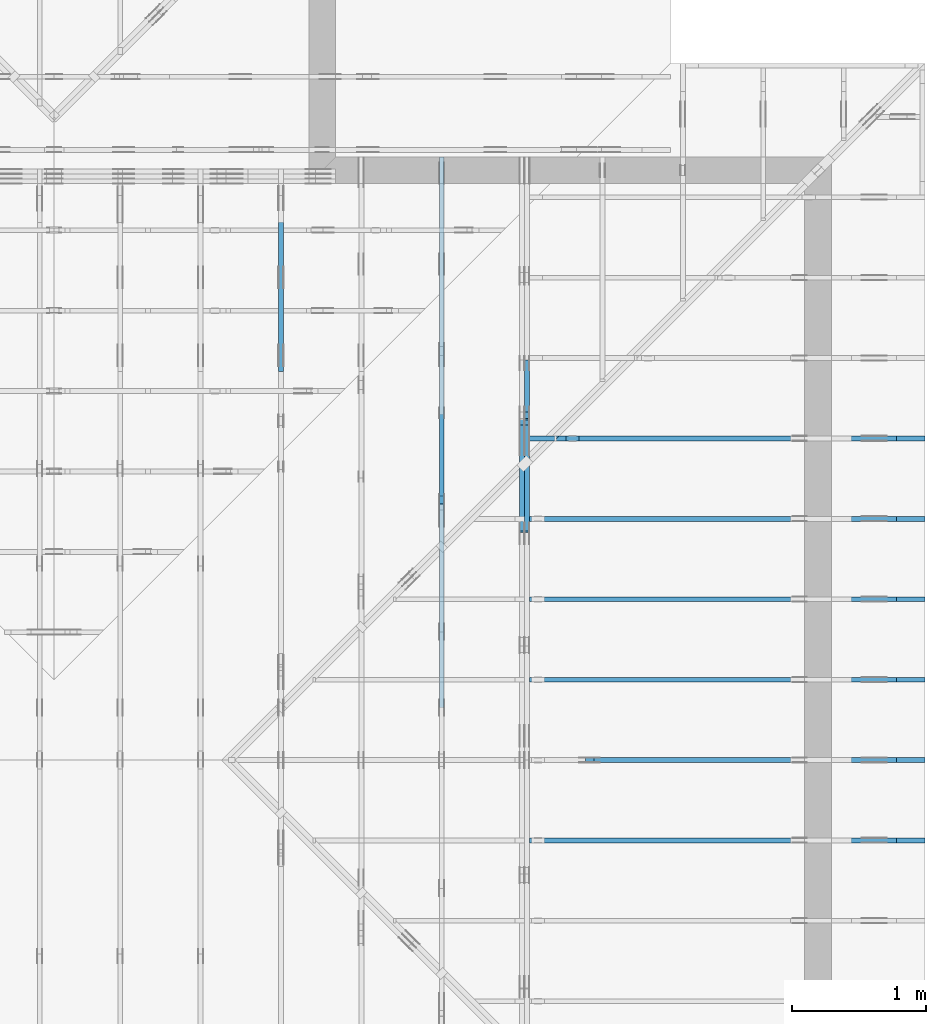
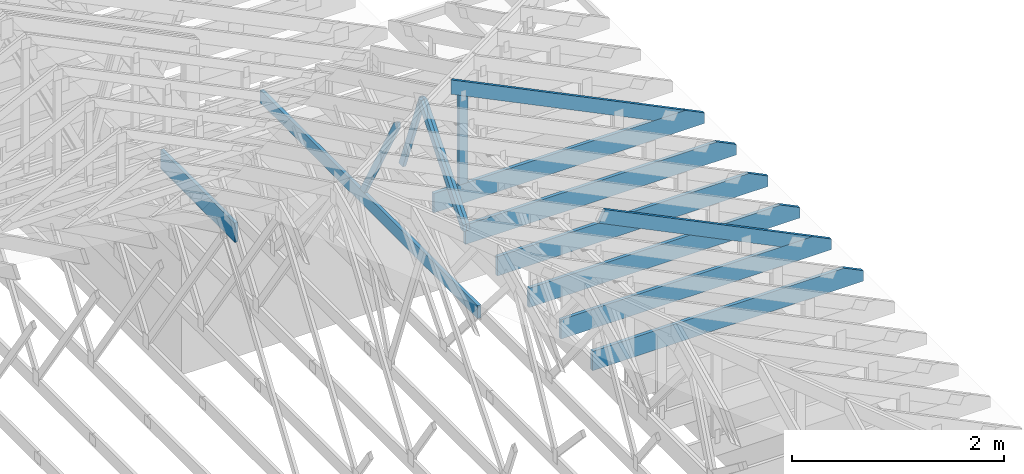
# One storey, part 35 of 159: 15 members, 9 elements without a shape of their own.
"""IFC2X3 building model written with IfcOpenShell, lengths in millimetres."""

from ifc_helpers import new_model, si_unit, frame, origin, origin_with_axes, origin_2d, place, context, project, spatial, faceted_brep, element, aggregate, save


model = new_model("IFC2X3")

# Units and contexts
model_context = context("Model", 3, precision=1e-05, world=origin())
plan_context = context("Plan", 2, precision=1e-05, world=origin_2d())
ifc_project = project(units=[si_unit("LENGTHUNIT", "METRE", prefix="MILLI"), si_unit("AREAUNIT", "SQUARE_METRE"), si_unit("VOLUMEUNIT", "CUBIC_METRE"), si_unit("SOLIDANGLEUNIT", "STERADIAN"), si_unit("PLANEANGLEUNIT", "RADIAN"), si_unit("MASSUNIT", "GRAM"), si_unit("TIMEUNIT", "SECOND"), si_unit("THERMODYNAMICTEMPERATUREUNIT", "DEGREE_CELSIUS"), si_unit("LUMINOUSINTENSITYUNIT", "LUMEN")], contexts=[model_context, plan_context])

# Site, building, storey
site_placement = place(None, origin_with_axes())
site = spatial("IfcSite", under=ifc_project, at=site_placement, CompositionType="ELEMENT")
building_placement = place(site_placement, origin_with_axes())
building = spatial("IfcBuilding", under=site, at=building_placement, Name="Plan 1", CompositionType="ELEMENT")
storey_placement = place(building_placement, origin_with_axes())
storey = spatial("IfcBuildingStorey", under=building, at=storey_placement, Name="Etasje 1", CompositionType="ELEMENT", Elevation=0.0)

# Assembly, member
assembly_1_placement = place(storey_placement, frame((16311.022261404749, -699.9989301294839, 1.1021457184401395e-15), z_axis=(1.0, -6.123031769111886e-17, 6.123031769111886e-17), x_axis=(6.123031769111886e-17, 1.0, 0.0)))
assembly_1 = element("IfcElementAssembly", 1, at=assembly_1_placement, inside=storey, Name="V8 (33)", AssemblyPlace="FACTORY", PredefinedType="TRUSS")
member_1_placement = place(assembly_1_placement, frame((8099.998930119851, 0.0, -36.0), z_axis=(0.0, 0.0, 1.0), x_axis=(1.0, 0.0, 0.0)))
member_1 = element("IfcMember", 2, at=member_1_placement, Name="V8-U19", context=model_context, shape_type="Brep", body=[
    faceted_brep([(1402.0000933176489, 223.0, 36.0), (9.331764886155725e-05, 223.0, 36.0), (9.331764886155725e-05, 0.0, 36.0), (1402.0000933176489, 0.0, 36.0), (9.331764886155725e-05, 223.0, 1.1427738571962853e-20), (1402.0000933176489, 223.0, 1.7168982223363585e-13), (1402.0000933176489, 0.0, 1.7168982223363585e-13), (9.331764886155725e-05, 0.0, 1.1427738571962853e-20), (0.0, 0.0, 0.0), (2.204291436880279e-15, -2.6993892992798474e-31, 36.0), (2.951301312711929e-14, 223.0, 36.0), (2.7308721690239013e-14, 223.0, -1.6721217048316832e-30), (1402.0, -2.5753471620884594e-13, 1.5768932489959775e-29), (1402.0, -2.5533042477196566e-13, 36.0), (4.049083948919771e-31, 2.204291436880279e-15, 36.0), (0.0, 0.0, 0.0), (1402.0, 223.0, 0.0), (1402.0, 223.0, 36.0), (1402.0, 0.0, 36.0), (1402.0, 0.0, 0.0), (0.0, 223.0, 0.0), (-1.3496946496399237e-31, 223.0, 36.0), (1402.0, 222.99999999999991, 36.0), (1402.0, 222.99999999999991, -4.733165431326071e-30)], [[[0, 1, 2, 3]], [[4, 5, 6, 7]], [[8, 9, 10, 11]], [[12, 13, 14, 15]], [[16, 17, 18, 19]], [[20, 21, 22, 23]]]),
])
aggregate(assembly_1, [member_1])

# Assembly, members
assembly_2_placement = place(storey_placement, frame((18074.541652722903, -699.9989301294845, 4.408582873760558e-15), z_axis=(-1.0, 1.836909530733566e-16, 6.123031769111886e-17), x_axis=(-1.836909530733566e-16, -1.0, 0.0)))
assembly_2 = element("IfcElementAssembly", 3, at=assembly_2_placement, inside=storey, Name="V5 (30)", AssemblyPlace="FACTORY", PredefinedType="TRUSS")
member_2_placement = place(assembly_2_placement, frame((-7784.008629309485, 1261.0239014078534, -71.99999999999999), z_axis=(0.0, 0.0, 1.0), x_axis=(-0.3612308951582944, -0.9324764020516215, 0.0)))
member_2 = element("IfcMember", 4, at=member_2_placement, Name="V5-D49", context=model_context, shape_type="Brep", body=[
    faceted_brep([(1084.9109850654727, 73.000426766278, 36.0), (62.15332242535737, 73.000426766278, 36.0), (6.463713430093776e-05, 36.500128102201415, 36.0), (39.3830811553712, 0.0001626723005756503, 36.0), (1113.1905312820863, 0.0001626723005756503, 36.0), (62.15332242535737, 73.000426766278, 7.611335355326349e-15), (1084.9109850654727, 73.000426766278, 1.328588885642872e-13), (1113.1905312820863, 0.0001626723005756503, 1.3632201976229506e-13), (39.3830811553712, 0.0001626723005756503, 4.82287714159699e-15), (6.463713430093776e-05, 36.500128102201415, 7.91550453577987e-21), (3.552713678800501e-15, 36.500210312128736, 0.0), (5.329070518200751e-15, 36.500210312128736, 36.0), (62.15334871027269, 73.00021031312829, 36.0), (62.15334871027269, 73.00021031312829, 7.888609052210118e-31), (39.38304675078666, 0.00021031312735075858, 1.9721522630525295e-31), (39.38304675078666, 0.00021031312735075858, 36.0), (7.105427357601002e-15, 36.50021031212874, 36.0), (7.105427357601002e-15, 36.50021031212874, -5.9164567891575885e-31), (1113.1904498091412, 0.00021031312619447325, 1.532860281653061e-29), (1113.1904498091412, 0.00021031312619667754, 36.0), (39.38304675078666, 0.0002103131273476588, 36.0), (39.38304675078666, 0.0002103131273454545, 5.423042565202193e-31), (1084.9110689169952, 73.00021031312644, 9.978856970719965e-31), (1084.9110689169952, 73.00021031312644, 36.0), (1113.1904498091412, 0.0002103131264448166, 36.0), (1113.1904498091412, 0.0002103131264448166, 1.2391235632630343e-30), (62.15334871027267, 73.00021031312826, 0.0), (62.15334871027267, 73.00021031312826, 36.0), (1084.9110689169952, 73.00021031312639, 36.0), (1084.9110689169952, 73.00021031312639, -3.944304526105059e-30)], [[[0, 1, 2, 3, 4]], [[5, 6, 7, 8, 9]], [[10, 11, 12, 13]], [[14, 15, 16, 17]], [[18, 19, 20, 21]], [[22, 23, 24, 25]], [[26, 27, 28, 29]]]),
])
member_3_placement = place(assembly_2_placement, frame((-7778.067645290552, 1224.537567565171, -36.0), z_axis=(0.0, 0.0, 1.0), x_axis=(0.6383914022219089, -0.7697119055654169, 0.0)))
member_3 = element("IfcMember", 5, at=member_3_placement, Name="V5-D38", context=model_context, shape_type="Brep", body=[
    faceted_brep([(1274.730361228223, 73.00027403103468, 36.0), (30.27278213358659, 73.00027403103468, 36.0), (0.0, 36.500021054841454, 36.0), (62.15355977314812, 0.00024289300472446484, 36.0), (1301.1849762534966, 0.00024289300472446484, 36.0), (1331.4577583870832, 36.500021054841454, 36.0), (30.27278213358659, 73.00027403103468, 3.707224134867068e-15), (1274.730361228223, 73.00027403103468, 1.5610428997703762e-13), (1331.4577583870832, 36.500021054841454, 1.6305116307669217e-13), (1301.1849762534966, 0.00024289300472446484, 1.5934393894182512e-13), (62.15355977314812, 0.00024289300472446484, 7.61136442108761e-15), (0.0, 36.500021054841454, 0.0), (4.0309500946023036e-05, 36.5001175513462, 0.0), (4.0309500946023036e-05, 36.5001175513462, 36.0), (30.272777437697194, 73.0001175521693, 36.0), (30.272777437697194, 73.0001175521693, -1.9721522630525295e-31), (62.15338902084478, 0.00011755217019882025, -3.944304526105059e-31), (62.15338902084478, 0.00011755217020237296, 36.0), (4.0309500946023036e-05, 36.500117551346186, 36.0), (4.030950094424668e-05, 36.500117551346186, 7.888609052210118e-31), (1301.1850737500954, 0.00011755216778175121, -1.928557785518386e-29), (1301.1850737500954, 0.0001175521677839555, 36.0), (62.15338902084477, 0.00011755217021251681, 36.0), (62.15338902084477, 0.00011755217021031252, -9.212099082196412e-31), (1331.4578108775677, 36.50011755220032, -1.262177448353619e-29), (1331.4578108775677, 36.50011755220032, 36.0), (1301.1850737500954, 0.00011755216746678343, 36.0), (1301.1850737500954, 0.00011755216746678343, 0.0), (1274.7302208736946, 73.00011755216656, 6.310887241768095e-30), (1274.7302208736946, 73.00011755216656, 36.0), (1331.4578108775677, 36.50011755220021, 36.0), (1331.4578108775677, 36.50011755220021, 0.0), (30.272777437697187, 73.00011755216929, 0.0), (30.272777437697187, 73.00011755216929, 36.0), (1274.7302208736946, 73.00011755216644, 36.0), (1274.7302208736946, 73.00011755216644, -7.099748146989106e-30)], [[[0, 1, 2, 3, 4, 5]], [[6, 7, 8, 9, 10, 11]], [[12, 13, 14, 15]], [[16, 17, 18, 19]], [[20, 21, 22, 23]], [[24, 25, 26, 27]], [[28, 29, 30, 31]], [[32, 33, 34, 35]]]),
])
member_4_placement = place(assembly_2_placement, frame((-7778.067645290552, 1224.537567565171, -72.0), z_axis=(0.0, 0.0, 1.0), x_axis=(0.6383914022219089, -0.7697119055654169, 0.0)))
member_4 = element("IfcMember", 6, at=member_4_placement, Name="V5-D38", context=model_context, shape_type="Brep", body=[
    faceted_brep([(1274.730361228223, 73.00027403103468, 36.0), (30.27278213358659, 73.00027403103468, 36.0), (0.0, 36.500021054841454, 36.0), (62.15355977314812, 0.00024289300472446484, 36.0), (1301.1849762534966, 0.00024289300472446484, 36.0), (1331.4577583870832, 36.500021054841454, 36.0), (30.27278213358659, 73.00027403103468, 3.707224134867068e-15), (1274.730361228223, 73.00027403103468, 1.5610428997703762e-13), (1331.4577583870832, 36.500021054841454, 1.6305116307669217e-13), (1301.1849762534966, 0.00024289300472446484, 1.5934393894182512e-13), (62.15355977314812, 0.00024289300472446484, 7.61136442108761e-15), (0.0, 36.500021054841454, 0.0), (4.0309500946023036e-05, 36.5001175513462, 0.0), (4.0309500946023036e-05, 36.5001175513462, 36.0), (30.272777437697194, 73.0001175521693, 36.0), (30.272777437697194, 73.0001175521693, -1.9721522630525295e-31), (62.15338902084478, 0.00011755217019882025, -3.944304526105059e-31), (62.15338902084478, 0.00011755217020237296, 36.0), (4.0309500946023036e-05, 36.500117551346186, 36.0), (4.030950094424668e-05, 36.500117551346186, 7.888609052210118e-31), (1301.1850737500954, 0.00011755216778175121, -1.928557785518386e-29), (1301.1850737500954, 0.0001175521677839555, 36.0), (62.15338902084477, 0.00011755217021251681, 36.0), (62.15338902084477, 0.00011755217021031252, -9.212099082196412e-31), (1331.4578108775677, 36.50011755220032, -1.262177448353619e-29), (1331.4578108775677, 36.50011755220032, 36.0), (1301.1850737500954, 0.00011755216746678343, 36.0), (1301.1850737500954, 0.00011755216746678343, 0.0), (1274.7302208736946, 73.00011755216656, 6.310887241768095e-30), (1274.7302208736946, 73.00011755216656, 36.0), (1331.4578108775677, 36.50011755220021, 36.0), (1331.4578108775677, 36.50011755220021, 0.0), (30.272777437697187, 73.00011755216929, 0.0), (30.272777437697187, 73.00011755216929, 36.0), (1274.7302208736946, 73.00011755216644, 36.0), (1274.7302208736946, 73.00011755216644, -7.099748146989106e-30)], [[[0, 1, 2, 3, 4, 5]], [[6, 7, 8, 9, 10, 11]], [[12, 13, 14, 15]], [[16, 17, 18, 19]], [[20, 21, 22, 23]], [[24, 25, 26, 27]], [[28, 29, 30, 31]], [[32, 33, 34, 35]]]),
])
aggregate(assembly_2, [member_2, member_3, member_4])

assembly_3_placement = place(storey_placement, frame((17475.02226140475, -699.9989301294827, 1.1021457184401395e-15), z_axis=(-1.0, 1.836909530733566e-16, 6.123031769111886e-17), x_axis=(-1.836909530733566e-16, -1.0, 0.0)))
assembly_3 = element("IfcElementAssembly", 7, at=assembly_3_placement, inside=storey, Name="V6 (31)", AssemblyPlace="FACTORY", PredefinedType="TRUSS")
member_5_placement = place(assembly_3_placement, frame((-5591.18115234375, 371.0, -36.0), z_axis=(0.0, 0.0, 1.0), x_axis=(-1.0, 1.2246063538223773e-16, 0.0)))
member_5 = element("IfcMember", 8, at=member_5_placement, Name="V6-U36", context=model_context, shape_type="Brep", body=[
    faceted_brep([(4108.81787109375, 148.0000000000005, 36.0), (0.0, 148.0000000000005, 36.0), (0.0, 0.0, 36.0), (4108.81787109375, 0.0, 36.0), (0.0, 148.0000000000005, 0.0), (4108.81787109375, 148.0000000000005, 5.03168447164034e-13), (4108.81787109375, 0.0, 5.03168447164034e-13), (0.0, 0.0, 0.0), (0.00014333613216876984, 5.684341886080801e-13, 0.0), (0.00014333613217097413, 5.684341886080801e-13, 36.0), (0.0001433361321890983, 148.00000000000057, 36.0), (0.000143336132186894, 148.00000000000057, -1.1097494219785373e-30), (4108.817771630158, -1.8631846188442574e-13, 4.2733203972373513e-29), (4108.817771630158, -1.8411417044754546e-13, 36.0), (0.00014333613216876984, 5.706384556983927e-13, 36.0), (0.00014333613216876984, 5.684341642615124e-13, 1.4907480704810918e-36), (4108.817771630158, 148.0000000000005, 0.0), (4108.817771630158, 148.0000000000005, 36.0), (4108.817771630158, 5.115907697472721e-13, 36.0), (4108.817771630158, 5.115907697472721e-13, 0.0), (0.00014333613216876984, 148.00000000000057, 0.0), (0.00014333613216876984, 148.00000000000057, 36.0), (4108.817771630158, 148.0000000000003, 36.0), (4108.817771630158, 148.0000000000003, -1.262177448353619e-29)], [[[0, 1, 2, 3]], [[4, 5, 6, 7]], [[8, 9, 10, 11]], [[12, 13, 14, 15]], [[16, 17, 18, 19]], [[20, 21, 22, 23]]]),
])
member_6_placement = place(assembly_3_placement, frame((-7146.339640948873, 1575.5658671851734, -36.0), z_axis=(0.0, 0.0, 1.0), x_axis=(-0.4866653205033153, -0.8735884991341206, 0.0)))
member_6 = element("IfcMember", 9, at=member_6_placement, Name="V6-D35", context=model_context, shape_type="Brep", body=[
    faceted_brep([(1338.2034959983775, 73.00023667841288, 36.0), (54.10344853321567, 73.00023667841288, 36.0), (5.7935560107580386e-05, 36.500086590488536, 36.0), (52.36370903164243, 0.0, 36.0), (1378.8709421020376, 0.0, 36.0), (54.10344853321567, 73.00023667841288, 6.6255426837477885e-15), (1338.2034959983775, 73.00023667841288, 1.6387725039069313e-13), (1378.8709421020376, 0.0, 1.6885741167992024e-13), (52.36370903164243, 0.0, 6.412493078985552e-15), (5.7935560107580386e-05, 36.500086590488536, 7.094825502000119e-21), (3.552713678800501e-15, 36.50018743795044, -7.888609052210118e-31), (3.552713678800501e-15, 36.50018743795043, 36.0), (54.103407708736086, 73.00018743826783, 36.0), (54.103407708736086, 73.00018743826783, -1.1832913578315177e-30), (52.36365352459869, 0.0001874382687496734, 1.4480364826565833e-30), (52.36365352459869, 0.0001874382687532261, 36.0), (0.0, 36.500187437950444, 36.0), (0.0, 36.500187437950444, -1.2863440234418975e-31), (1378.8709182405728, 0.00018743826732536963, 3.2609593040059477e-29), (1378.8709182405728, 0.00018743826732757393, 36.0), (52.3636535245987, 0.00018743826874941641, 36.0), (52.3636535245987, 0.00018743826874721212, 1.2383744588737617e-30), (1338.2035234294517, 73.00018743826786, -1.8103283027266085e-30), (1338.2035234294517, 73.00018743826786, 36.0), (1378.8709182405728, 0.00018743826774425543, 36.0), (1378.8709182405728, 0.00018743826774425543, -2.0678278207804665e-30), (54.103407708736086, 73.00018743826786, 0.0), (54.103407708736086, 73.00018743826786, 36.0), (1338.2035234294517, 73.00018743826777, 36.0), (1338.2035234294517, 73.00018743826777, -4.733165431326071e-30)], [[[0, 1, 2, 3, 4]], [[5, 6, 7, 8, 9]], [[10, 11, 12, 13]], [[14, 15, 16, 17]], [[18, 19, 20, 21]], [[22, 23, 24, 25]], [[26, 27, 28, 29]]]),
])
aggregate(assembly_3, [member_5, member_6])

assembly_4_placement = place(storey_placement, frame((21100.012663101486, 4518.000534935253, 1.1021457184401395e-15), z_axis=(1.2246063538223773e-16, 1.0, 6.123031769111886e-17), x_axis=(-1.0, 1.2246063538223773e-16, 0.0)))
assembly_4 = element("IfcElementAssembly", 10, at=assembly_4_placement, inside=storey, Name="S13 (51)", AssemblyPlace="FACTORY", PredefinedType="TRUSS")
member_7_placement = place(assembly_4_placement, frame((276.0602239501104, 89.97847693121035, -36.000001952341165), z_axis=(0.0, 0.0, 1.0), x_axis=(0.8987940462991673, 0.4383711467890768, 0.0)))
member_7 = element("IfcMember", 11, at=member_7_placement, Name="S13-O47", context=model_context, shape_type="Brep", body=[
    faceted_brep([(3.1607657433596614e-06, 148.0000031496927, 1.95234116517895e-06), (3.1607657433596614e-06, 148.0000031496927, 36.000001952341165), (2513.9243195670156, 148.00000314969256, 36.000001952341165), (2513.9243195670156, 148.00000314969256, 1.95234116517895e-06), (303.4449717131315, 3.150361024495396e-06, 1.95234116517895e-06), (303.4449717131315, 3.150361024495396e-06, 36.000001952341165), (-7.105427357601002e-15, 148.00000469130106, 36.000001952341165), (-7.105427357601002e-15, 148.00000469130106, 1.95234116517895e-06), (2513.9243359555576, 3.1509190183728126e-06, 1.95234116517895e-06), (2513.9243359555576, 3.150919020577104e-06, 36.000001952341165), (303.4450879086828, 3.1509194266221437e-06, 36.000001952341165), (303.4450879086828, 3.1509194244178523e-06, 1.95234116517895e-06), (2513.924335955558, 148.0000027752492, 1.878353664608312e-06), (2513.9243359555576, 148.0000027752492, 36.00000195234116), (2513.9243359555576, 0.0, 36.00000255341423), (2513.924335955558, 0.0, 6.462348535570529e-27), (2513.9243359555576, 148.0000031509196, 36.000001952341165), (1.954930735337257e-05, 148.0000031509196, 36.000001952341165), (303.4450879086829, 3.1503610102845414e-06, 36.000001952341165), (2513.9243359555576, 3.1503610102845414e-06, 36.000001952341165), (1.9549308035493596e-05, 148.0000031496926, 1.9523411651789527e-06), (2513.9243359555576, 148.0000031496926, 1.952341473035722e-06), (2513.9243359555576, 3.1509196105616866e-06, 1.952341473035722e-06), (303.44508790868326, 3.1509196105616866e-06, 1.9523412023390284e-06)], [[[0, 1, 2, 3]], [[4, 5, 6, 7]], [[8, 9, 10, 11]], [[12, 13, 14, 15]], [[16, 17, 18, 19]], [[20, 21, 22, 23]]]),
])
member_8_placement = place(assembly_4_placement, frame((2953.4710103785837, 223.0, -36.0), z_axis=(0.0, 0.0, 1.0), x_axis=(-1.0, 1.2246063538223773e-16, 0.0)))
member_8 = element("IfcMember", 12, at=member_8_placement, Name="S13-U10", context=model_context, shape_type="Brep", body=[
    faceted_brep([(2953.4710103785947, 223.00000000000037, 36.0), (6.311295874183998e-05, 223.00000000000037, 36.0), (6.311295874183998e-05, 0.0, 36.0), (2742.289720705732, 0.0, 36.0), (2953.4700660270973, 102.9995422363285, 36.0), (6.311295874183998e-05, 223.00000000000037, 7.728853028378678e-21), (2953.4710103785947, 223.00000000000037, 3.616839365139823e-13), (2953.4700660270973, 102.9995422363285, 3.6168382086809796e-13), (2742.289720705732, 0.0, 3.358225415998032e-13), (6.311295874183998e-05, 0.0, 7.728853028378678e-21), (0.0, 0.0, 0.0), (2.204291436880279e-15, -2.6993892992798474e-31, 36.0), (2.951301312711929e-14, 223.0, 36.0), (2.7308721690239013e-14, 223.0, -1.6721217048316832e-30), (2742.2897146949763, -5.037338112955833e-13, 5.172702487036636e-29), (2742.2897146949763, -5.01529519858703e-13, 36.0), (4.049083948919771e-31, 2.204291436880279e-15, 36.0), (0.0, 0.0, 0.0), (2953.4700660271083, 102.9995394088487, -7.573064690121713e-29), (2953.4700660271083, 102.9995394088487, 36.0), (2742.289714694976, 1.1368683772161603e-12, 36.0), (2742.289714694976, 1.1368683772161603e-12, -6.310887241768094e-29), (2953.4692552825763, 223.00000000000037, -1.0746508677980613e-19), (2953.4692552825763, 223.00000000000037, 36.0), (2953.4692552825763, 102.99953940884771, 36.0), (2953.4692552825763, 102.99953940884771, -4.9642145257273734e-20), (0.0, 223.0, 0.0), (0.0, 223.0, 36.0), (2953.4710103785947, 223.00000000000048, 36.0), (2953.4710103785947, 223.00000000000048, 6.310887241768095e-30)], [[[0, 1, 2, 3, 4]], [[5, 6, 7, 8, 9]], [[10, 11, 12, 13]], [[14, 15, 16, 17]], [[18, 19, 20, 21]], [[22, 23, 24, 25]], [[26, 27, 28, 29]]]),
])
aggregate(assembly_4, [member_7, member_8])

# Assembly, member
assembly_5_placement = place(storey_placement, frame((21100.012663101486, 5117.993668449257, 1.1021457184401395e-15), z_axis=(1.2246063538223773e-16, 1.0, 6.123031769111886e-17), x_axis=(-1.0, 1.2246063538223773e-16, 0.0)))
assembly_5 = element("IfcElementAssembly", 13, at=assembly_5_placement, inside=storey, Name="S14 (49)", AssemblyPlace="FACTORY", PredefinedType="TRUSS")
member_9_placement = place(assembly_5_placement, frame((2953.4710103785837, 223.0, -36.0), z_axis=(0.0, 0.0, 1.0), x_axis=(-1.0, 1.2246063538223773e-16, 0.0)))
member_9 = element("IfcMember", 14, at=member_9_placement, Name="S14-U10", context=model_context, shape_type="Brep", body=[
    faceted_brep([(2953.4710103785947, 223.00000000000037, 36.0), (6.311295874183998e-05, 223.00000000000037, 36.0), (6.311295874183998e-05, 0.0, 36.0), (2742.289720705732, 0.0, 36.0), (2953.4700660270973, 102.9995422363285, 36.0), (6.311295874183998e-05, 223.00000000000037, 7.728853028378678e-21), (2953.4710103785947, 223.00000000000037, 3.616839365139823e-13), (2953.4700660270973, 102.9995422363285, 3.6168382086809796e-13), (2742.289720705732, 0.0, 3.358225415998032e-13), (6.311295874183998e-05, 0.0, 7.728853028378678e-21), (0.0, 0.0, 0.0), (2.204291436880279e-15, -2.6993892992798474e-31, 36.0), (2.951301312711929e-14, 223.0, 36.0), (2.7308721690239013e-14, 223.0, -1.6721217048316832e-30), (2742.2897146949763, -5.037338112955833e-13, 5.172702487036636e-29), (2742.2897146949763, -5.01529519858703e-13, 36.0), (4.049083948919771e-31, 2.204291436880279e-15, 36.0), (0.0, 0.0, 0.0), (2953.4700660271087, 102.99953940797445, 4.3026404708613384e-30), (2953.4700660271087, 102.99953940797445, 36.0), (2742.2897146949763, 0.0, 36.0), (2742.2897146949763, 0.0, 5.0266658494811856e-30), (2953.4692552825763, 223.00000000000037, -1.0746508677980613e-19), (2953.4692552825763, 223.00000000000037, 36.0), (2953.4692552825763, 102.9995394079746, 36.0), (2953.4692552825763, 102.9995394079746, -4.9642145257273734e-20), (0.0, 223.0, 0.0), (0.0, 223.0, 36.0), (2953.4710103785947, 223.00000000000048, 36.0), (2953.4710103785947, 223.00000000000048, 6.310887241768095e-30)], [[[0, 1, 2, 3, 4]], [[5, 6, 7, 8, 9]], [[10, 11, 12, 13]], [[14, 15, 16, 17]], [[18, 19, 20, 21]], [[22, 23, 24, 25]], [[26, 27, 28, 29]]]),
])
aggregate(assembly_5, [member_9])

assembly_6_placement = place(storey_placement, frame((21100.012663101486, 5717.993668449257, 1.1021457184401395e-15), z_axis=(1.2246063538223773e-16, 1.0, 6.123031769111886e-17), x_axis=(-1.0, 1.2246063538223773e-16, 0.0)))
assembly_6 = element("IfcElementAssembly", 15, at=assembly_6_placement, inside=storey, Name="S15 (47)", AssemblyPlace="FACTORY", PredefinedType="TRUSS")
member_10_placement = place(assembly_6_placement, frame((2953.4710103785837, 223.0, -36.0), z_axis=(0.0, 0.0, 1.0), x_axis=(-1.0, 1.2246063538223773e-16, 0.0)))
member_10 = element("IfcMember", 16, at=member_10_placement, Name="S15-U10", context=model_context, shape_type="Brep", body=[
    faceted_brep([(2953.4710103785947, 223.00000000000037, 36.0), (6.311295874183998e-05, 223.00000000000037, 36.0), (6.311295874183998e-05, 0.0, 36.0), (2742.289720705732, 0.0, 36.0), (2953.4700660270973, 102.9995422363285, 36.0), (6.311295874183998e-05, 223.00000000000037, 7.728853028378678e-21), (2953.4710103785947, 223.00000000000037, 3.616839365139823e-13), (2953.4700660270973, 102.9995422363285, 3.6168382086809796e-13), (2742.289720705732, 0.0, 3.358225415998032e-13), (6.311295874183998e-05, 0.0, 7.728853028378678e-21), (0.0, 0.0, 0.0), (2.204291436880279e-15, -2.6993892992798474e-31, 36.0), (2.951301312711929e-14, 223.0, 36.0), (2.7308721690239013e-14, 223.0, -1.6721217048316832e-30), (2742.2897146949763, -5.037338112955833e-13, 5.172702487036636e-29), (2742.2897146949763, -5.01529519858703e-13, 36.0), (4.049083948919771e-31, 2.204291436880279e-15, 36.0), (0.0, 0.0, 0.0), (2953.4700660271087, 102.99953940797445, 4.3026404708613384e-30), (2953.4700660271087, 102.99953940797445, 36.0), (2742.2897146949763, 0.0, 36.0), (2742.2897146949763, 0.0, 5.0266658494811856e-30), (2953.4692552825763, 223.00000000000037, -1.0746508677980613e-19), (2953.4692552825763, 223.00000000000037, 36.0), (2953.4692552825763, 102.9995394079746, 36.0), (2953.4692552825763, 102.9995394079746, -4.9642145257273734e-20), (0.0, 223.0, 0.0), (0.0, 223.0, 36.0), (2953.4710103785947, 223.00000000000048, 36.0), (2953.4710103785947, 223.00000000000048, 6.310887241768095e-30)], [[[0, 1, 2, 3, 4]], [[5, 6, 7, 8, 9]], [[10, 11, 12, 13]], [[14, 15, 16, 17]], [[18, 19, 20, 21]], [[22, 23, 24, 25]], [[26, 27, 28, 29]]]),
])
aggregate(assembly_6, [member_10])

assembly_7_placement = place(storey_placement, frame((21100.012663101486, 6317.993668449257, 1.1021457184401395e-15), z_axis=(1.2246063538223773e-16, 1.0, 6.123031769111886e-17), x_axis=(-1.0, 1.2246063538223773e-16, 0.0)))
assembly_7 = element("IfcElementAssembly", 17, at=assembly_7_placement, inside=storey, Name="S16 (45)", AssemblyPlace="FACTORY", PredefinedType="TRUSS")
member_11_placement = place(assembly_7_placement, frame((2953.4710103785837, 223.0, -36.0), z_axis=(0.0, 0.0, 1.0), x_axis=(-1.0, 1.2246063538223773e-16, 0.0)))
member_11 = element("IfcMember", 18, at=member_11_placement, Name="S16-U10", context=model_context, shape_type="Brep", body=[
    faceted_brep([(2953.4710103785947, 223.00000000000037, 36.0), (6.311295874183998e-05, 223.00000000000037, 36.0), (6.311295874183998e-05, 0.0, 36.0), (2742.289720705732, 0.0, 36.0), (2953.4700660270973, 102.9995422363285, 36.0), (6.311295874183998e-05, 223.00000000000037, 7.728853028378678e-21), (2953.4710103785947, 223.00000000000037, 3.616839365139823e-13), (2953.4700660270973, 102.9995422363285, 3.6168382086809796e-13), (2742.289720705732, 0.0, 3.358225415998032e-13), (6.311295874183998e-05, 0.0, 7.728853028378678e-21), (0.0, 0.0, 0.0), (2.204291436880279e-15, -2.6993892992798474e-31, 36.0), (2.951301312711929e-14, 223.0, 36.0), (2.7308721690239013e-14, 223.0, -1.6721217048316832e-30), (2742.2897146949763, -5.037338112955833e-13, 5.172702487036636e-29), (2742.2897146949763, -5.01529519858703e-13, 36.0), (4.049083948919771e-31, 2.204291436880279e-15, 36.0), (0.0, 0.0, 0.0), (2953.4700660271083, 102.9995394088487, -7.573064690121713e-29), (2953.4700660271083, 102.9995394088487, 36.0), (2742.289714694976, 1.1368683772161603e-12, 36.0), (2742.289714694976, 1.1368683772161603e-12, -6.310887241768094e-29), (2953.4692552825763, 223.00000000000037, -1.0746508677980613e-19), (2953.4692552825763, 223.00000000000037, 36.0), (2953.4692552825763, 102.99953940884771, 36.0), (2953.4692552825763, 102.99953940884771, -4.9642145257273734e-20), (0.0, 223.0, 0.0), (0.0, 223.0, 36.0), (2953.4710103785947, 223.00000000000048, 36.0), (2953.4710103785947, 223.00000000000048, 6.310887241768095e-30)], [[[0, 1, 2, 3, 4]], [[5, 6, 7, 8, 9]], [[10, 11, 12, 13]], [[14, 15, 16, 17]], [[18, 19, 20, 21]], [[22, 23, 24, 25]], [[26, 27, 28, 29]]]),
])
aggregate(assembly_7, [member_11])

assembly_8_placement = place(storey_placement, frame((21100.012663101486, 3918.0074014212582, 1.1021457184401395e-15), z_axis=(1.2246063538223773e-16, 1.0, 6.123031769111886e-17), x_axis=(-1.0, 1.2246063538223773e-16, 0.0)))
assembly_8 = element("IfcElementAssembly", 19, at=assembly_8_placement, inside=storey, Name="S14 (43)", AssemblyPlace="FACTORY", PredefinedType="TRUSS")
member_12_placement = place(assembly_8_placement, frame((2953.4710103785837, 223.0, -36.0), z_axis=(0.0, 0.0, 1.0), x_axis=(-1.0, 1.2246063538223773e-16, 0.0)))
member_12 = element("IfcMember", 20, at=member_12_placement, Name="S14-U10", context=model_context, shape_type="Brep", body=[
    faceted_brep([(2953.4710103785947, 223.00000000000037, 36.0), (6.311295874183998e-05, 223.00000000000037, 36.0), (6.311295874183998e-05, 0.0, 36.0), (2742.289720705732, 0.0, 36.0), (2953.4700660270973, 102.9995422363285, 36.0), (6.311295874183998e-05, 223.00000000000037, 7.728853028378678e-21), (2953.4710103785947, 223.00000000000037, 3.616839365139823e-13), (2953.4700660270973, 102.9995422363285, 3.6168382086809796e-13), (2742.289720705732, 0.0, 3.358225415998032e-13), (6.311295874183998e-05, 0.0, 7.728853028378678e-21), (0.0, 0.0, 0.0), (2.204291436880279e-15, -2.6993892992798474e-31, 36.0), (2.951301312711929e-14, 223.0, 36.0), (2.7308721690239013e-14, 223.0, -1.6721217048316832e-30), (2742.2897146949763, -5.037338112955833e-13, 5.172702487036636e-29), (2742.2897146949763, -5.01529519858703e-13, 36.0), (4.049083948919771e-31, 2.204291436880279e-15, 36.0), (0.0, 0.0, 0.0), (2953.4700660271087, 102.99953940797445, 4.3026404708613384e-30), (2953.4700660271087, 102.99953940797445, 36.0), (2742.2897146949763, 0.0, 36.0), (2742.2897146949763, 0.0, 5.0266658494811856e-30), (2953.4692552825763, 223.00000000000037, -1.0746508677980613e-19), (2953.4692552825763, 223.00000000000037, 36.0), (2953.4692552825763, 102.9995394079746, 36.0), (2953.4692552825763, 102.9995394079746, -4.9642145257273734e-20), (0.0, 223.0, 0.0), (0.0, 223.0, 36.0), (2953.4710103785947, 223.00000000000048, 36.0), (2953.4710103785947, 223.00000000000048, 6.310887241768095e-30)], [[[0, 1, 2, 3, 4]], [[5, 6, 7, 8, 9]], [[10, 11, 12, 13]], [[14, 15, 16, 17]], [[18, 19, 20, 21]], [[22, 23, 24, 25]], [[26, 27, 28, 29]]]),
])
aggregate(assembly_8, [member_12])

# Assembly, members
assembly_9_placement = place(storey_placement, frame((21100.012663101486, 6917.993668449257, 1.1021457184401395e-15), z_axis=(1.2246063538223773e-16, 1.0, 6.123031769111886e-17), x_axis=(-1.0, 1.2246063538223773e-16, 0.0)))
assembly_9 = element("IfcElementAssembly", 21, at=assembly_9_placement, inside=storey, Name="S17 (38)", AssemblyPlace="FACTORY", PredefinedType="TRUSS")
member_13_placement = place(assembly_9_placement, frame((276.0602103296882, 89.97847343758126, -36.00000021759626), z_axis=(0.0, 0.0, 1.0), x_axis=(0.8987940462991671, 0.43837114678907707, 0.0)))
member_13 = element("IfcMember", 22, at=member_13_placement, Name="S17-O40", context=model_context, shape_type="Brep", body=[
    faceted_brep([(2843.71416516714, 148.00000083083285, 2.253344518976519e-06), (2803.6604981698138, 147.99999513788782, 35.99999718740128), (2731.47607421875, 3.2117259252117947e-07, 36.000000217595925), (2771.529744161271, 0.0, 0.0), (9.693473077732051e-05, 148.00000031882803, 2.1759625923323256e-07), (9.693473077732051e-05, 148.00000031882803, 36.00000021759626), (2803.660497325355, 148.00000031882786, 36.00000021759626), (2843.7141663011853, 148.00000031882786, 2.1759625923323256e-07), (303.444985486592, 3.196135480720841e-07, 2.1759625923323256e-07), (303.444985486592, 3.196135480720841e-07, 36.00000021759626), (1.3773460658228487e-05, 148.00000186055382, 36.00000021759626), (1.3773460658228487e-05, 148.00000186055382, 2.1759625923323256e-07), (2771.529744075847, 3.211978763508813e-07, 2.1759625923323256e-07), (2731.4760751000167, 3.211978859126693e-07, 36.00000021759626), (303.4450272789718, 3.211983319200066e-07, 36.00000021759626), (303.4450272789718, 3.2119832971571517e-07, 2.1759625923323256e-07), (2803.660499572754, 148.00000032117282, 36.00000021759626), (0.0, 148.00000032117282, 36.00000021759626), (303.44506835937534, 3.196136617589218e-07, 36.00000021759626), (2731.47607421875, 3.196136617589218e-07, 36.00000021759626), (5.5854300910596066e-05, 148.00000032057847, 2.175962592332394e-07), (2843.7141671824256, 148.00000032057847, 2.1759660747627632e-07), (2771.5297418284217, 3.188029040757101e-07, 2.1759659863652574e-07), (303.4448800730511, 3.188029040757101e-07, 2.1759629639328536e-07)], [[[0, 1, 2, 3]], [[4, 5, 6, 7]], [[8, 9, 10, 11]], [[12, 13, 14, 15]], [[16, 17, 18, 19]], [[20, 21, 22, 23]]]),
])
member_14_placement = place(assembly_9_placement, frame((2953.4710103785837, 223.0, -36.0), z_axis=(0.0, 0.0, 1.0), x_axis=(-1.0, 1.2246063538223773e-16, 0.0)))
member_14 = element("IfcMember", 23, at=member_14_placement, Name="S17-U10", context=model_context, shape_type="Brep", body=[
    faceted_brep([(2953.4710103785947, 223.00000000000037, 36.0), (6.311295874183998e-05, 223.00000000000037, 36.0), (6.311295874183998e-05, 0.0, 36.0), (2742.289720705732, 0.0, 36.0), (2953.4700660270973, 102.9995422363285, 36.0), (6.311295874183998e-05, 223.00000000000037, 7.728853028378678e-21), (2953.4710103785947, 223.00000000000037, 3.616839365139823e-13), (2953.4700660270973, 102.9995422363285, 3.6168382086809796e-13), (2742.289720705732, 0.0, 3.358225415998032e-13), (6.311295874183998e-05, 0.0, 7.728853028378678e-21), (0.0, 0.0, 0.0), (2.204291436880279e-15, -2.6993892992798474e-31, 36.0), (2.951301312711929e-14, 223.0, 36.0), (2.7308721690239013e-14, 223.0, -1.6721217048316832e-30), (2742.2897146949763, -5.037338112955833e-13, 5.172702487036636e-29), (2742.2897146949763, -5.01529519858703e-13, 36.0), (4.049083948919771e-31, 2.204291436880279e-15, 36.0), (0.0, 0.0, 0.0), (2953.4700660271087, 102.99953940795899, 7.573064690121713e-29), (2953.4700660271087, 102.99953940795899, 36.0), (2742.2897146949767, -6.821210263296962e-13, 36.0), (2742.2897146949767, -6.821210263296962e-13, 6.310887241768094e-29), (2953.469255282577, 223.00000000000037, -1.0746508672931903e-19), (2953.469255282577, 223.00000000000037, 36.0), (2953.469255282577, 102.99953940796004, 36.0), (2953.469255282577, 102.99953940796004, -4.9642145206786636e-20), (0.0, 223.0, 0.0), (0.0, 223.0, 36.0), (2953.4710103785947, 223.00000000000048, 36.0), (2953.4710103785947, 223.00000000000048, 6.310887241768095e-30)], [[[0, 1, 2, 3, 4]], [[5, 6, 7, 8, 9]], [[10, 11, 12, 13]], [[14, 15, 16, 17]], [[18, 19, 20, 21]], [[22, 23, 24, 25]], [[26, 27, 28, 29]]]),
])
member_15_placement = place(assembly_9_placement, frame((2583.094643307137, 1262.9921875, -36.0), z_axis=(0.0, 0.0, 1.0), x_axis=(-1.836909530733566e-16, -1.0, 0.0)))
member_15 = element("IfcMember", 24, at=member_15_placement, Name="S17-S9", context=model_context, shape_type="Brep", body=[
    faceted_brep([(1039.9921875, 98.00008325536328, 36.0), (0.0, 98.00008325536328, 36.0), (47.7978515625, 8.325536327902228e-05, 36.0), (1039.9921875, 8.325536327902228e-05, 36.0), (0.0, 98.00008325536328, 0.0), (1039.9921875, 98.00008325536328, 1.273581040738133e-13), (1039.9921875, 8.325536327902228e-05, 1.273581040738133e-13), (47.7978515625, 8.325536327902228e-05, 5.853355272249634e-15), (47.79783779839636, 1.4548362514688051e-11, 0.0), (47.79783779839636, 1.4548362514688051e-11, 36.0), (4.411894046540965e-05, 97.99999999999957, 36.0), (4.411894046540965e-05, 97.99999999999957, -2.7610131682735413e-30), (1039.992187500124, -6.409764103942921e-13, 3.924718924095545e-29), (1039.992187500124, -6.387721189574118e-13, 36.0), (47.79783779839636, 1.4524660369182353e-11, 36.0), (47.79783779839636, 1.4522456077745473e-11, 1.8037931514576675e-30), (1039.992187500124, 98.0, 4.0515896092151166e-27), (1039.992187500124, 98.0, 36.0), (1039.992187500124, 0.0, 36.0), (1039.992187500124, 0.0, 0.0), (4.4118940422777086e-05, 97.99999999999955, 0.0), (4.4118940422777086e-05, 97.99999999999955, 36.0), (1039.9921875000578, 97.99999999999994, 36.0), (1039.9921875000578, 97.99999999999994, -3.1554436208840472e-30)], [[[0, 1, 2, 3]], [[4, 5, 6, 7]], [[8, 9, 10, 11]], [[12, 13, 14, 15]], [[16, 17, 18, 19]], [[20, 21, 22, 23]]]),
])
aggregate(assembly_9, [member_13, member_14, member_15])

save(model, "model.ifc")
